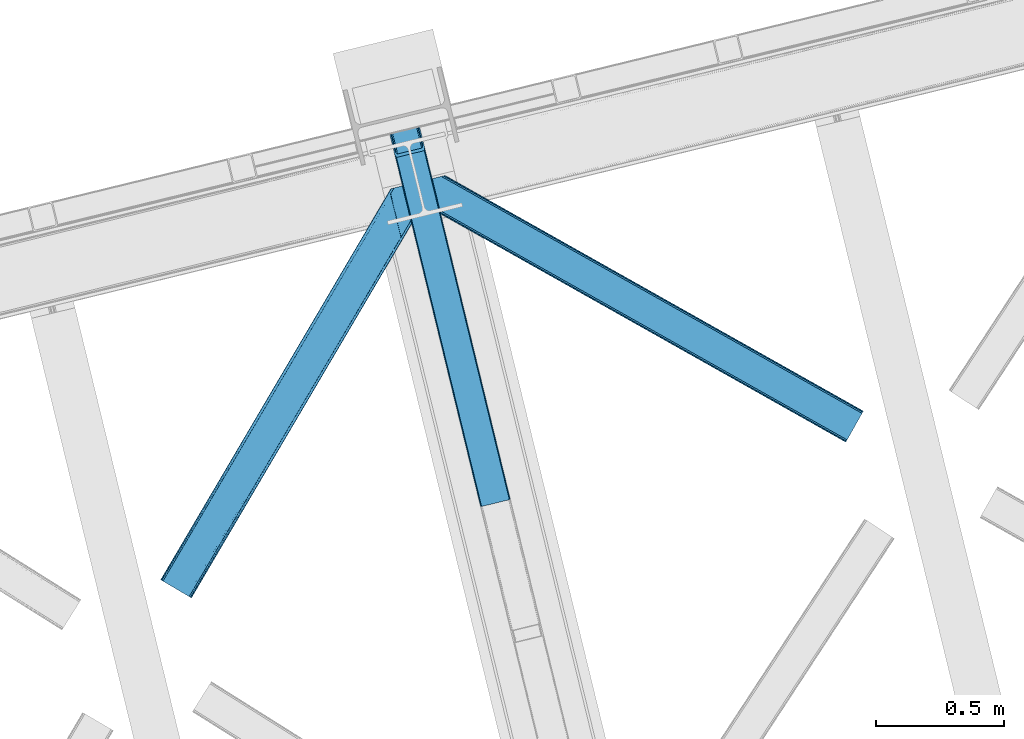
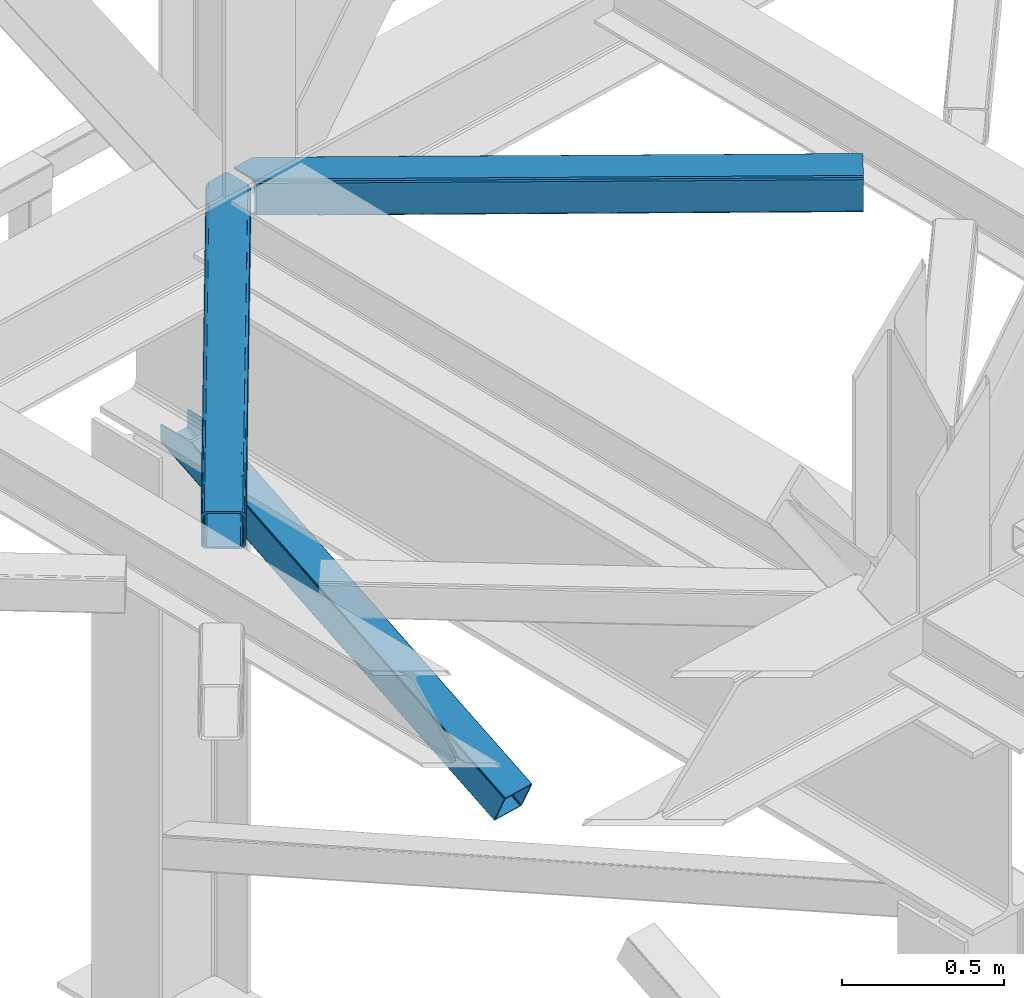
# One storey, part 39 of 93: 3 members.
"""IFC4 building model written with IfcOpenShell, lengths in millimetres."""

from ifc_helpers import new_model, entity, si_unit, converted_unit, derived_unit, direction, frame, origin, place, context, subcontext, project, spatial, triangles, type_object, element, save


model = new_model("IFC4")

# Units and contexts
model_context = context("Model", 3, precision=0.01, world=origin(), true_north=direction((6.12303176911189e-17, 1.0)))
plan_context = context("Plan", 3, precision=0.01, world=origin(), true_north=direction((6.12303176911189e-17, 1.0)))
body_context = subcontext(model_context, "Body", "Model", "MODEL_VIEW")
ifc_project = project(units=[si_unit("LENGTHUNIT", "METRE", prefix="MILLI"), si_unit("AREAUNIT", "SQUARE_METRE"), si_unit("VOLUMEUNIT", "CUBIC_METRE"), converted_unit("PLANEANGLEUNIT", "DEGREE", entity("IfcRatioMeasure", 0.0174532925199433), si_unit("PLANEANGLEUNIT", "RADIAN"), dimensions=[0, 0, 0, 0, 0, 0, 0]), si_unit("MASSUNIT", "GRAM", prefix="KILO"), derived_unit("MASSDENSITYUNIT", [(si_unit("MASSUNIT", "GRAM", prefix="KILO"), 1), (si_unit("LENGTHUNIT", "METRE"), -3)]), derived_unit("MOMENTOFINERTIAUNIT", [(si_unit("LENGTHUNIT", "METRE"), 4)]), si_unit("TIMEUNIT", "SECOND"), si_unit("FREQUENCYUNIT", "HERTZ"), si_unit("THERMODYNAMICTEMPERATUREUNIT", "DEGREE_CELSIUS"), derived_unit("THERMALTRANSMITTANCEUNIT", [(si_unit("MASSUNIT", "GRAM", prefix="KILO"), 1), (si_unit("THERMODYNAMICTEMPERATUREUNIT", "KELVIN"), -1), (si_unit("TIMEUNIT", "SECOND"), -3)]), derived_unit("VOLUMETRICFLOWRATEUNIT", [(si_unit("LENGTHUNIT", "METRE"), 3), (si_unit("TIMEUNIT", "SECOND"), -1)]), derived_unit("MASSFLOWRATEUNIT", [(si_unit("MASSUNIT", "GRAM", prefix="KILO"), 1), (si_unit("TIMEUNIT", "SECOND"), -1)]), derived_unit("ROTATIONALFREQUENCYUNIT", [(si_unit("TIMEUNIT", "SECOND"), -1)]), si_unit("ELECTRICCURRENTUNIT", "AMPERE"), si_unit("ELECTRICVOLTAGEUNIT", "VOLT"), si_unit("POWERUNIT", "WATT"), si_unit("FORCEUNIT", "NEWTON", prefix="KILO"), si_unit("ILLUMINANCEUNIT", "LUX"), si_unit("LUMINOUSFLUXUNIT", "LUMEN"), si_unit("LUMINOUSINTENSITYUNIT", "CANDELA"), derived_unit("USERDEFINED", [(si_unit("MASSUNIT", "GRAM", prefix="KILO"), -1), (si_unit("LENGTHUNIT", "METRE"), -2), (si_unit("TIMEUNIT", "SECOND"), 3), (si_unit("LUMINOUSFLUXUNIT", "LUMEN"), 1)]), derived_unit("LINEARVELOCITYUNIT", [(si_unit("LENGTHUNIT", "METRE"), 1), (si_unit("TIMEUNIT", "SECOND"), -1)]), si_unit("PRESSUREUNIT", "PASCAL"), derived_unit("USERDEFINED", [(si_unit("LENGTHUNIT", "METRE"), -2), (si_unit("MASSUNIT", "GRAM", prefix="KILO"), 1), (si_unit("TIMEUNIT", "SECOND"), -2)]), derived_unit("LINEARFORCEUNIT", [(si_unit("MASSUNIT", "GRAM", prefix="KILO"), 1), (si_unit("LENGTHUNIT", "METRE"), 1), (si_unit("TIMEUNIT", "SECOND"), -2), (si_unit("LENGTHUNIT", "METRE"), -1)]), derived_unit("PLANARFORCEUNIT", [(si_unit("MASSUNIT", "GRAM", prefix="KILO"), 1), (si_unit("LENGTHUNIT", "METRE"), 1), (si_unit("TIMEUNIT", "SECOND"), -2), (si_unit("LENGTHUNIT", "METRE"), -2)])], contexts=[model_context, plan_context])

# Site, building, storey
site_placement = place(None, origin())
site = spatial("IfcSite", under=ifc_project, at=site_placement, CompositionType="ELEMENT")
building_placement = place(site_placement, origin())
building = spatial("IfcBuilding", under=site, at=building_placement, CompositionType="ELEMENT")
storey_placement = place(building_placement, frame((0.0, 0.0, 15900.0)))
storey = spatial("IfcBuildingStorey", under=building, at=storey_placement, CompositionType="ELEMENT", Elevation=15900.0)

# Members
member_type_1 = type_object("IfcMemberType", PredefinedType="BRACE")
member_1_placement = place(storey_placement, frame((-49464.9481567383, 7483.36647949219, 1850.35374755859)))
element("IfcMember", 1, at=member_1_placement, inside=storey, type_object=member_type_1, ObjectType="Steel Vertical Brace", PredefinedType="BRACE", context=body_context, shape_type="Tessellation", body=[
    triangles([(109.783996582031, 1519.24680175781, 671.707836914062), (462.204345703125, 73.4908630371092, 0.0), (359.21993408203, 48.3871627807621, 0.0), (6.79958496093604, 1494.14310150146, 671.707836914062), (464.855346679688, 73.9117675781254, 0.48601684570167), (467.213342285155, 73.843167114258, 1.86965332031104), (112.188500976561, 1519.8328125, 672.832186889649), (468.906262207034, 73.2949447631836, 3.93929443359229), (114.593005371091, 1520.41940460205, 673.956536865233), (469.682958984376, 72.3502349853516, 6.38100585937354), (115.588293457033, 1520.66183166504, 676.672650146484), (116.583581542967, 1520.90484008789, 679.387600708007), (353.099377441409, 43.9310394287113, 6.38100585937354), (0.0, 1492.48564453125, 679.387600708007), (0.99528808593459, 1492.72807159424, 676.672650146484), (353.355175781253, 45.128059387207, 3.93929443359229), (1.99057617187646, 1492.97108001709, 673.956536865233), (354.606262207031, 46.3954238891602, 1.86965332031104), (4.39508056640625, 1493.55767211914, 672.832186889649), (356.666601562501, 47.5395401000978, 0.48601684570167), (144.93533935547, 1404.59159088135, 741.646591186523), (116.583581542967, 1520.90484008789, 741.646591186523), (480.012561035153, 29.9807281494141, 102.993713378906), (28.3517578125029, 1376.17239532471, 741.646591186523), (0.0, 1492.48564453125, 741.646591186523), (363.428979492186, 1.5615325927738, 102.993713378906), (476.445336914061, 26.3722274780275, 108.888702392578), (144.460949707034, 1388.29607391357, 741.646591186523), (142.168066406251, 1386.40316619873, 741.646591186523), (473.896655273435, 25.5251861572269, 109.37471923828), (478.505676269531, 27.5169250488279, 107.505065917969), (145.795751953126, 1392.41733398437, 741.646591186523), (479.75676269531, 28.7837081909183, 105.435424804688), (145.963183593747, 1398.13907775879, 741.646591186523), (39.1790039062471, 1361.29946594238, 741.646591186523), (370.907592773438, 0.421485900878906, 109.37471923828), (364.205676269528, 0.61682281494177, 105.435424804688), (30.4120971679658, 1369.97219238281, 741.646591186523), (365.90324707031, 0.0686004638673694, 107.505065917969), (33.1933227539048, 1364.96900939941, 741.646591186523), (368.256591796875, 0.0, 108.888702392578), (36.2722045898408, 1361.92384643555, 741.646591186523), (138.056689453122, 1403.03994140625, 741.646591186523), (137.200927734375, 1415.21477966309, 741.646591186523), (111.728063964845, 1519.72061004639, 741.646591186523), (138.22412109375, 1408.76284790039, 741.646591186523), (136.726538085939, 1398.91926269531, 741.646591186523), (134.429003906247, 1397.02635498047, 741.646591186523), (35.169946289061, 1377.96065826416, 741.646591186523), (32.3887207031221, 1382.96384124756, 741.646591186523), (30.333032226561, 1389.16346282959, 741.646591186523), (4.85551757812209, 1493.66987457275, 741.646591186523), (38.2534790039063, 1374.91549530029, 741.646591186523), (41.1602783203125, 1374.29111480713, 741.646591186523), (474.668701171875, 30.7952133178715, 98.4370147705085), (474.412902832031, 29.5981933593748, 100.87872619629), (473.157165527344, 28.3308288574217, 102.948367309571), (471.101477050783, 27.186712646484, 104.330841064453), (468.548144531247, 26.3390899658207, 104.816857910155), (375.279418945313, 3.60384979248011, 104.816857910155), (372.62841796875, 3.18294525146484, 104.330841064453), (370.270422363283, 3.25154571533221, 102.948367309571), (368.577502441403, 3.79976806640661, 100.87872619629), (367.796154785159, 4.74447784423865, 98.4370147705085), (111.728063964845, 1519.72061004639, 684.873312377931), (465.315783691403, 69.1678710937504, 10.9377044677749), (4.85551757812209, 1493.66987457275, 684.873312377931), (358.443237304688, 43.1165542602539, 10.9377044677749), (462.84151611328, 70.6602218627932, 6.42635192871239), (464.534436035159, 70.1125808715824, 8.49599304199364), (460.483520507813, 70.7294036865233, 5.04387817382667), (457.83251953125, 70.3079177856443, 4.557861328125), (359.954772949219, 45.5809387207028, 6.42635192871239), (362.01046142578, 46.7256362915041, 5.04387817382667), (358.699035644531, 44.3135742187496, 8.49599304199364), (364.563793945315, 47.5726776123047, 4.557861328125), (11.6551025390654, 1495.32733154297, 677.193548583986), (9.25059814452834, 1494.74132080078, 678.31789855957), (6.84609374999854, 1494.15531005859, 679.443411254884), (104.923828125, 1518.06257171631, 677.193548583986), (107.332983398439, 1518.64916381836, 678.31789855957), (109.73283691406, 1519.23517456055, 679.443411254884), (5.85080566406396, 1493.91288299561, 682.158361816408), (110.732775878903, 1519.47760162354, 682.158361816408)], [[1, 2, 3], [3, 4, 1], [5, 2, 1], [6, 5, 7], [8, 6, 9], [10, 8, 11], [11, 12, 10], [9, 11, 8], [7, 9, 6], [1, 7, 5], [13, 14, 15], [16, 15, 17], [18, 17, 19], [20, 19, 4], [4, 3, 20], [19, 20, 18], [17, 18, 16], [15, 16, 13], [12, 21, 10], [21, 12, 22], [23, 10, 21], [24, 14, 13], [24, 25, 14], [13, 26, 24], [27, 28, 29], [29, 30, 27], [31, 32, 28], [28, 27, 31], [33, 34, 32], [32, 31, 33], [23, 21, 34], [34, 33, 23], [30, 29, 35], [35, 36, 30], [37, 38, 26], [24, 26, 38], [39, 40, 37], [38, 37, 40], [41, 42, 39], [40, 39, 42], [36, 35, 41], [42, 41, 35], [43, 34, 21], [22, 44, 21], [44, 22, 45], [44, 46, 21], [46, 43, 21], [47, 34, 43], [32, 29, 28], [32, 34, 47], [32, 48, 29], [29, 48, 35], [47, 48, 32], [24, 38, 49], [49, 50, 24], [50, 51, 24], [51, 25, 24], [52, 25, 51], [38, 53, 49], [54, 40, 35], [54, 35, 48], [54, 53, 40], [35, 40, 42], [53, 38, 40], [44, 55, 46], [56, 46, 55], [46, 56, 43], [57, 43, 56], [43, 57, 47], [58, 47, 57], [47, 58, 48], [59, 48, 58], [48, 59, 54], [60, 54, 59], [54, 60, 61], [61, 53, 54], [53, 61, 62], [62, 49, 53], [49, 62, 63], [63, 50, 49], [50, 63, 64], [64, 51, 50], [44, 65, 66], [44, 45, 65], [66, 55, 44], [67, 51, 68], [51, 67, 52], [64, 68, 51], [55, 23, 56], [57, 33, 31], [31, 27, 57], [23, 55, 10], [23, 33, 57], [57, 56, 23], [59, 30, 36], [30, 58, 57], [59, 58, 30], [30, 57, 27], [6, 69, 5], [66, 10, 55], [69, 8, 10], [70, 10, 66], [8, 69, 6], [69, 2, 5], [10, 70, 69], [69, 71, 2], [2, 72, 3], [72, 2, 71], [62, 26, 63], [36, 60, 59], [61, 36, 62], [36, 61, 60], [62, 36, 41], [64, 63, 26], [41, 39, 62], [37, 62, 39], [64, 26, 13], [37, 26, 62], [73, 20, 3], [74, 73, 3], [75, 13, 73], [76, 3, 72], [3, 76, 74], [18, 20, 73], [13, 68, 64], [16, 73, 13], [68, 13, 75], [73, 16, 18], [77, 1, 4], [4, 19, 78], [19, 17, 15], [19, 79, 78], [4, 78, 77], [79, 19, 15], [80, 1, 77], [9, 7, 11], [7, 1, 81], [81, 82, 7], [7, 82, 11], [80, 81, 1], [11, 82, 12], [83, 14, 67], [15, 14, 79], [83, 79, 14], [25, 67, 14], [25, 52, 67], [12, 84, 65], [84, 12, 82], [65, 22, 12], [22, 65, 45], [72, 80, 76], [77, 76, 80], [66, 65, 84], [70, 84, 82], [69, 82, 81], [71, 81, 80], [80, 72, 71], [81, 71, 69], [82, 69, 70], [84, 70, 66], [74, 76, 77], [73, 74, 78], [75, 73, 79], [68, 75, 83], [83, 67, 68], [79, 83, 75], [78, 79, 73], [77, 78, 74]]),
])
member_type_2 = type_object("IfcMemberType", PredefinedType="BRACE")
member_2_placement = place(storey_placement, frame((-49332.8771484375, 7733.54713897705, 3511.0000579834)))
element("IfcMember", 2, at=member_2_placement, inside=storey, type_object=member_type_2, ObjectType="Steel Horizontal Brace", PredefinedType="BRACE", context=body_context, shape_type="Tessellation", body=[
    triangles([(1656.08961181641, 0.0, 122.500662231447), (1656.74538574219, 1.16039428710974, 129.197927856447), (23.8915649414048, 919.17296447754, 122.500662231447), (23.4590332031294, 920.94494934082, 129.197927856447), (1658.60573730469, 4.46600646972638, 134.874325561526), (22.2265502929731, 925.991734313965, 134.874325561526), (1661.39161376953, 9.41279754638708, 138.667117309571), (20.3894531250044, 933.544180297852, 138.667117309571), (1664.67513427734, 15.2484878540045, 139.999594116212), (18.2174926757798, 942.452938842774, 139.999594116212), (1656.08961181641, 0.0, 17.5000946044929), (23.8915649414048, 919.17296447754, 17.5000946044929), (1716.19757080078, 106.738252258301, 139.999594116212), (69.4469238281235, 1034.10722808838, 139.999594116212), (0.0, 1017.17919158936, 139.999594116212), (1719.4857421875, 112.573361206055, 138.667117309571), (78.971923828125, 1036.42917938232, 138.667117309571), (1722.27161865235, 117.520152282715, 134.874325561526), (87.0458496093779, 1038.39766387939, 134.874325561526), (1724.13197021485, 120.825764465332, 129.197927856447), (92.4408691406279, 1039.71269989014, 129.197927856447), (1724.78774414062, 121.986740112305, 122.500662231447), (94.3384277343794, 1040.17488098145, 122.500662231447), (1724.78774414062, 121.986740112305, 17.5000946044929), (94.3384277343794, 1040.17488098145, 17.5000946044929), (1656.74538574219, 1.16039428710974, 10.8028289794929), (1658.60573730469, 4.46600646972638, 5.12526855468968), (196.057800292969, 824.821165466309, 8.8831787109375), (196.076403808598, 825.066499328613, 8.50064392089917), (23.3706665039063, 921.307136535645, 10.8691040039084), (195.062512207034, 824.99848022461, 9.50058288574292), (195.732238769531, 824.878720092774, 9.08316650390771), (23.263696289061, 921.747807312012, 9.50058288574292), (195.220642089844, 828.57035522461, 5.12526855468968), (1664.67513427734, 15.2484878540045, 0.0), (1661.39161376953, 9.41279754638708, 1.33247680664135), (193.378894042973, 836.122801208497, 1.33247680664135), (191.206933593749, 845.031559753418, 0.0), (1716.19757080078, 106.738252258301, 0.0), (157.162499999999, 984.71082458496, 0.0), (191.346459960936, 843.22294921875, 9.20757751465135), (191.290649414063, 844.06824645996, 8.85411071777344), (191.104614257813, 845.460603332519, 8.41343994140698), (18.8686157226548, 939.774032592774, 9.50058288574292), (1724.13197021485, 120.825764465332, 10.8028289794929), (92.0548461914077, 1039.61851959229, 10.8702667236357), (150.921020507813, 1006.08800811768, 9.50058288574292), (1722.27161865235, 117.520152282715, 5.12526855468968), (153.148791503911, 1001.17202911377, 5.12526855468968), (152.293029785156, 1004.67588500977, 8.50064392089917), (151.60469970703, 1005.38223724365, 9.00061340332104), (91.5851074218735, 1039.50341033936, 9.50058288574292), (1719.4857421875, 112.573361206055, 1.33247680664135), (154.990539550781, 993.619583129884, 1.33247680664135), (156.250927734378, 986.702563476562, 9.11688537597729), (155.813745117186, 987.634483337403, 9.42384338378906), (156.692761230472, 985.76134185791, 8.80760192871094), (157.129943847656, 984.828840637208, 8.50064392089917), (155.316101074219, 988.061782836915, 9.50058288574292), (72.3118652343765, 1034.80544128418, 9.50058288574292), (159.43212890625, 975.399183654786, 6.99957275390625), (188.937304687504, 854.343782043456, 6.99957275390625), (1668.11213378907, 21.3475341796875, 6.99957275390625), (1712.76522216797, 100.639205932617, 6.99957275390625), (19.9569213867217, 935.303375244142, 12.1260040283232), (1662.0380859375, 10.5650527954103, 12.1260040283232), (1664.82396240235, 15.5124252319338, 8.3320495605476), (1659.52661132813, 6.09904632568396, 24.4996673583992), (1660.177734375, 7.26002197265643, 17.8035644531265), (21.6219360351606, 928.485186767578, 24.4996673583992), (21.1894042968779, 930.25717163086, 17.8035644531265), (1716.04874267578, 106.474314880371, 8.3320495605476), (1718.83927001953, 111.421105957032, 12.1260040283232), (77.0929687500029, 1035.9704864502, 12.1260040283232), (1720.69962158203, 114.726718139648, 17.8035644531265), (82.4879882812529, 1037.2861038208, 17.8035644531265), (1721.35074462891, 115.887112426758, 24.4996673583992), (84.3808959960952, 1037.74770355225, 24.4996673583992), (1659.52661132813, 6.09904632568396, 115.501089477541), (21.6219360351606, 928.485186767578, 115.501089477541), (21.1894042968779, 930.25717163086, 122.196029663086), (19.9569213867217, 935.303375244142, 127.87475280762), (15.9478637695356, 951.765161132812, 133.000021362306), (18.1198242187529, 942.855821228027, 131.667544555665), (0.0, 1017.17919158936, 133.000021362306), (1668.11213378907, 21.3475341796875, 133.000021362306), (1664.82396240235, 15.5124252319338, 131.667544555665), (1662.0380859375, 10.5650527954103, 127.87475280762), (1660.177734375, 7.26002197265643, 122.196029663086), (1718.83927001953, 111.421105957032, 127.87475280762), (1720.69962158203, 114.726718139648, 122.196029663086), (1721.35074462891, 115.887112426758, 115.501089477541), (1712.76522216797, 100.639205932617, 133.000021362306), (1716.04874267578, 106.474314880371, 131.667544555665), (77.0929687500029, 1035.9704864502, 127.87475280762), (69.0143920898481, 1034.00200195312, 131.667544555665), (82.4879882812529, 1037.2861038208, 122.196029663086), (59.4893920898467, 1031.68005065918, 133.000021362306), (84.3808959960952, 1037.74770355225, 115.501089477541)], [[1, 2, 3], [4, 3, 2], [2, 5, 4], [6, 4, 5], [5, 7, 6], [8, 6, 7], [7, 9, 8], [10, 8, 9], [11, 1, 12], [3, 12, 1], [13, 10, 9], [10, 13, 14], [15, 10, 14], [13, 16, 17], [17, 14, 13], [16, 18, 19], [19, 17, 16], [18, 20, 21], [21, 19, 18], [20, 22, 23], [23, 21, 20], [22, 24, 23], [25, 23, 24], [26, 11, 12], [27, 28, 29], [26, 30, 31], [31, 27, 26], [31, 32, 27], [30, 33, 31], [29, 34, 27], [35, 36, 37], [37, 38, 35], [36, 27, 34], [34, 37, 36], [12, 30, 26], [39, 35, 38], [38, 40, 39], [41, 42, 29], [42, 43, 29], [41, 31, 33], [33, 44, 41], [45, 46, 25], [46, 45, 47], [45, 48, 49], [49, 50, 45], [45, 50, 51], [51, 47, 45], [47, 52, 46], [48, 53, 54], [54, 49, 48], [53, 39, 40], [40, 54, 53], [25, 24, 45], [51, 55, 56], [50, 57, 55], [50, 58, 57], [47, 59, 52], [60, 52, 59], [61, 40, 62], [54, 58, 49], [58, 54, 40], [49, 58, 50], [40, 61, 58], [62, 40, 38], [37, 43, 38], [43, 37, 34], [38, 43, 62], [34, 29, 43], [63, 64, 62], [61, 62, 64], [63, 62, 43], [41, 65, 66], [41, 44, 65], [43, 66, 67], [66, 43, 42], [42, 41, 66], [43, 67, 63], [68, 69, 70], [71, 70, 69], [69, 66, 71], [65, 71, 66], [72, 58, 61], [57, 72, 55], [57, 58, 72], [56, 55, 72], [73, 74, 59], [59, 72, 73], [74, 60, 59], [73, 75, 76], [76, 74, 73], [75, 77, 78], [78, 76, 75], [61, 64, 72], [79, 68, 80], [70, 80, 68], [81, 6, 82], [80, 70, 3], [4, 81, 3], [81, 4, 6], [81, 80, 3], [70, 12, 3], [71, 65, 33], [33, 30, 71], [30, 12, 71], [70, 71, 12], [83, 10, 15], [10, 84, 8], [84, 10, 83], [15, 85, 83], [84, 82, 8], [44, 33, 65], [8, 82, 6], [86, 87, 84], [84, 83, 86], [87, 88, 82], [82, 84, 87], [88, 89, 81], [81, 82, 88], [89, 79, 80], [80, 81, 89], [20, 90, 91], [92, 24, 22], [20, 91, 22], [20, 18, 90], [91, 92, 22], [90, 18, 16], [93, 13, 9], [13, 94, 16], [94, 13, 93], [94, 90, 16], [45, 73, 48], [77, 24, 92], [24, 75, 45], [75, 24, 77], [45, 75, 73], [39, 64, 35], [53, 48, 73], [73, 72, 53], [72, 64, 39], [39, 53, 72], [88, 7, 5], [9, 86, 93], [9, 87, 86], [87, 9, 7], [88, 87, 7], [79, 1, 11], [2, 89, 88], [5, 2, 88], [89, 2, 1], [79, 89, 1], [36, 66, 27], [35, 64, 63], [63, 67, 35], [67, 66, 36], [36, 35, 67], [26, 27, 66], [11, 68, 79], [69, 11, 26], [11, 69, 68], [69, 26, 66], [95, 96, 17], [19, 95, 17], [19, 21, 97], [95, 19, 97], [97, 21, 23], [96, 14, 17], [15, 98, 85], [15, 14, 98], [96, 98, 14], [97, 23, 99], [78, 25, 76], [23, 78, 99], [25, 46, 76], [23, 25, 78], [52, 76, 46], [74, 76, 52], [60, 74, 52], [93, 83, 98], [93, 86, 83], [83, 85, 98], [77, 92, 99], [99, 78, 77], [92, 91, 99], [97, 99, 91], [91, 90, 97], [95, 97, 90], [90, 94, 95], [96, 95, 94], [94, 93, 96], [98, 96, 93]]),
])
member_type_3 = type_object("IfcMemberType", PredefinedType="BRACE")
member_3_placement = place(storey_placement, frame((-50348.2756347656, 7126.42373199463, 3511.0000579834)))
element("IfcMember", 3, at=member_3_placement, inside=storey, type_object=member_type_3, ObjectType="Steel Horizontal Brace", PredefinedType="BRACE", context=body_context, shape_type="Tessellation", body=[
    triangles([(105.565649414064, 8.87852783203198, 0.0), (15.0828002929702, 62.1485321044929, 0.0), (892.847827148435, 1346.13992614746, 0.0), (857.170935058595, 1492.50308532715, 0.0), (854.896655273435, 1501.83798065186, 1.33247680664135), (9.31105957031104, 65.5459991455082, 1.33247680664135), (852.966540527341, 1509.7520324707, 5.12526855468968), (4.4183349609375, 68.4266372680668, 5.12526855468968), (851.678247070311, 1515.03950042725, 10.8028289794929), (1.14876708984229, 70.3509384155277, 10.8028289794929), (851.222460937497, 1516.89636383057, 17.5000946044929), (0.0, 71.027059936524, 17.5000946044929), (893.638476562497, 1342.89826354981, 0.155804443362285), (111.337390136716, 5.48106079101581, 1.33247680664135), (899.559045410155, 1344.34178009033, 1.33247680664135), (912.390820312496, 1347.47007751465, 10.8028289794929), (914.195361328122, 1347.90958557129, 17.5000946044929), (120.643798828125, 0.0, 17.5000946044929), (119.499682617185, 0.676121520996276, 10.8028289794929), (907.251599121089, 1346.21724700928, 5.12526855468968), (116.230114746089, 2.60042266845721, 5.12526855468968), (902.498400878903, 1345.05743408203, 17.9802978515654), (893.638476562497, 1342.89826354981, 9.69243164062573), (897.768457031249, 1343.90517883301, 12.1260040283232), (903.726232910158, 1345.35683441162, 19.4999725341804), (914.195361328122, 1347.90958557129, 19.4999725341804), (1011.61732177734, 1513.38669433594, 19.4999725341804), (1008.98957519531, 1524.16103668213, 19.4999725341804), (1011.61732177734, 1513.38669433594, 122.500662231447), (120.643798828125, 0.0, 122.500662231447), (114.61160888672, 3.5515274047857, 24.4996673583992), (1009.24072265625, 1523.14423828125, 24.4996673583992), (113.462841796871, 4.22706756591833, 17.8035644531265), (110.197924804685, 6.15195007324292, 12.1260040283232), (105.305200195311, 9.03200683593786, 8.3320495605476), (99.5334594726519, 12.4294738769531, 6.99957275390625), (892.685046386716, 1346.80035095215, 8.88434143066479), (890.471228027345, 1355.89747009277, 6.99957275390625), (21.114990234375, 58.5975860595709, 6.99957275390625), (859.547534179685, 1482.74496002197, 6.99957275390625), (853.961828613283, 1505.66042175293, 18.5000335693367), (851.222460937497, 1516.89636383057, 18.5000335693367), (854.096704101561, 1505.10929260254, 17.8803039550803), (855.343139648438, 1499.99448852539, 12.1260040283232), (857.273254394531, 1492.08043670654, 8.3320495605476), (1009.24072265625, 1523.14423828125, 115.501089477541), (114.61160888672, 3.5515274047857, 115.501089477541), (1008.78493652344, 1525.00110168457, 122.196029663086), (113.462841796871, 4.22706756591833, 122.196029663086), (1007.49664306641, 1530.28915100098, 127.87475280762), (110.197924804685, 6.15195007324292, 127.87475280762), (1005.57117919921, 1538.20320281983, 131.667544555665), (105.305200195311, 9.03200683593786, 131.667544555665), (1003.29224853515, 1547.53809814453, 133.000021362306), (99.5334594726519, 12.4294738769531, 133.000021362306), (851.952648925777, 1518.13291625977, 19.4999725341804), (854.580395507808, 1507.35857391358, 19.4999725341804), (851.780566406247, 1517.84049224854, 19.2639404296897), (854.43156738281, 1506.95045928955, 19.2592895507842), (851.589880371095, 1517.5149307251, 19.0000030517585), (854.268786621091, 1506.50978851318, 19.0000030517585), (851.394543457027, 1517.1887878418, 18.736065673831), (854.110656738281, 1506.06853637695, 18.7407165527366), (908.014343261719, 1598.12687072754, 19.4999725341804), (897.545214843747, 1595.57411956787, 19.4999725341804), (1011.16618652343, 1515.24355773926, 129.197927856447), (1009.8778930664, 1520.53160705566, 134.874325561526), (1008.43146972656, 1526.45624542236, 137.999716186525), (986.311889648438, 1617.21175231934, 137.999716186525), (986.311889648438, 1617.21175231934, 133.000021362306), (897.545214843747, 1595.57411956787, 122.500662231447), (0.0, 71.027059936524, 122.500662231447), (7.18095703124709, 66.7999923706057, 17.8035644531265), (10.4505249023423, 64.875109863282, 12.1260040283232), (6.03218994140479, 67.4755325317383, 24.4996673583992), (907.028356933595, 1597.88560638428, 24.4996673583992), (15.3432495117158, 61.9950531005861, 8.3320495605476), (908.832897949214, 1598.32569580078, 122.196029663086), (899.349755859374, 1596.01362762451, 129.197927856447), (904.48897705078, 1597.26645812988, 134.874325561526), (930.738537597652, 1603.66548614502, 133.000021362306), (910.246765136719, 1598.67044219971, 137.999716186525), (921.664672851563, 1601.45341186523, 131.667544555665), (913.972119140621, 1599.57852630615, 127.87475280762), (907.028356933595, 1597.88560638428, 115.501089477541), (21.114990234375, 58.5975860595709, 133.000021362306), (6.03218994140479, 67.4755325317383, 115.501089477541), (15.3432495117158, 61.9950531005861, 131.667544555665), (10.4505249023423, 64.875109863282, 127.87475280762), (7.18095703124709, 66.7999923706057, 122.196029663086), (119.499682617185, 0.676121520996276, 129.197927856447), (116.230114746089, 2.60042266845721, 134.874325561526), (111.337390136716, 5.48106079101581, 138.667117309571), (105.565649414064, 8.87852783203198, 139.999594116212), (15.0828002929702, 62.1485321044929, 139.999594116212), (9.31105957031104, 65.5459991455082, 138.667117309571), (4.4183349609375, 68.4266372680668, 134.874325561526), (1.14876708984229, 70.3509384155277, 129.197927856447), (896.991760253906, 1576.15611877441, 137.999716186525), (938.18924560547, 1407.14434204102, 137.999716186525), (899.024194335936, 1563.59525756836, 139.999594116212), (897.042919921871, 1571.7232498169, 138.999655151369), (896.801074218747, 1573.1371170044, 138.639212036134), (896.926647949214, 1575.15443572998, 138.211331176761), (896.86153564453, 1574.14170684815, 138.427597045898), (937.477661132813, 1407.08620605469, 138.29272155762), (937.082336425781, 1408.09544677734, 138.646188354494), (936.682360839841, 1409.1046875, 138.999655151369), (934.701086425783, 1417.23267974854, 139.999594116212)], [[1, 2, 3], [4, 3, 2], [5, 4, 6], [2, 6, 4], [7, 5, 8], [6, 8, 5], [9, 7, 10], [8, 10, 7], [11, 9, 12], [10, 12, 9], [1, 3, 13], [13, 14, 1], [13, 15, 14], [16, 17, 18], [18, 19, 16], [20, 16, 19], [19, 21, 20], [15, 20, 21], [21, 14, 15], [20, 22, 16], [23, 24, 15], [23, 15, 13], [15, 24, 20], [16, 25, 17], [20, 24, 22], [16, 22, 25], [26, 17, 25], [26, 25, 27], [28, 27, 25], [27, 29, 26], [30, 26, 29], [26, 18, 17], [30, 18, 26], [31, 32, 25], [25, 33, 31], [25, 22, 33], [32, 28, 25], [33, 22, 24], [34, 24, 23], [23, 35, 34], [36, 35, 37], [37, 38, 36], [23, 37, 35], [24, 34, 33], [39, 36, 38], [38, 40, 39], [9, 11, 41], [11, 42, 41], [43, 9, 41], [43, 7, 9], [44, 7, 43], [5, 44, 45], [44, 5, 7], [4, 5, 45], [45, 40, 4], [37, 23, 13], [37, 3, 38], [3, 40, 38], [40, 3, 4], [37, 13, 3], [46, 32, 31], [31, 47, 46], [48, 46, 49], [47, 49, 46], [50, 48, 51], [49, 51, 48], [52, 50, 53], [51, 53, 50], [54, 52, 55], [53, 55, 52], [56, 57, 58], [59, 58, 57], [58, 59, 60], [61, 60, 59], [60, 61, 62], [63, 62, 61], [62, 63, 42], [41, 42, 63], [57, 56, 64], [65, 64, 56], [66, 48, 67], [46, 29, 27], [27, 32, 46], [32, 27, 28], [48, 29, 46], [66, 29, 48], [50, 68, 67], [52, 68, 50], [67, 48, 50], [52, 54, 68], [54, 69, 68], [70, 69, 54], [71, 60, 62], [58, 60, 71], [71, 56, 58], [56, 71, 65], [42, 12, 72], [12, 42, 11], [71, 42, 72], [42, 71, 62], [73, 74, 44], [75, 73, 43], [43, 41, 75], [43, 57, 75], [64, 76, 57], [75, 57, 76], [44, 43, 73], [45, 44, 74], [74, 77, 45], [40, 45, 77], [77, 39, 40], [78, 79, 80], [81, 82, 69], [69, 70, 81], [81, 83, 82], [84, 82, 83], [80, 82, 84], [78, 71, 79], [85, 71, 78], [80, 84, 78], [65, 76, 64], [85, 65, 71], [76, 65, 85], [86, 54, 55], [54, 86, 81], [70, 54, 81], [76, 85, 87], [87, 75, 76], [83, 81, 86], [86, 88, 83], [84, 83, 88], [88, 89, 84], [78, 84, 89], [89, 90, 78], [85, 78, 90], [90, 87, 85], [91, 51, 49], [47, 18, 30], [91, 49, 30], [91, 92, 51], [49, 47, 30], [51, 92, 93], [55, 94, 95], [94, 53, 93], [53, 94, 55], [53, 51, 93], [19, 34, 21], [31, 18, 47], [18, 33, 19], [33, 18, 31], [19, 33, 34], [1, 36, 2], [14, 21, 34], [34, 35, 14], [35, 36, 1], [1, 14, 35], [89, 96, 97], [95, 86, 55], [95, 88, 86], [88, 95, 96], [89, 88, 96], [87, 72, 12], [98, 90, 89], [97, 98, 89], [90, 98, 72], [87, 90, 72], [6, 74, 8], [2, 36, 39], [39, 77, 2], [77, 74, 6], [6, 2, 77], [10, 8, 74], [12, 75, 87], [73, 12, 10], [12, 73, 75], [73, 10, 74], [99, 68, 82], [99, 100, 68], [68, 69, 82], [96, 95, 101], [101, 102, 96], [97, 96, 103], [104, 97, 105], [104, 99, 97], [97, 103, 105], [82, 80, 99], [97, 99, 80], [102, 103, 96], [79, 71, 98], [72, 98, 71], [80, 79, 97], [98, 97, 79], [92, 67, 100], [100, 93, 92], [67, 68, 100], [106, 107, 93], [94, 93, 107], [107, 108, 94], [108, 109, 94], [66, 67, 92], [92, 91, 66], [29, 66, 91], [91, 30, 29], [95, 94, 109], [109, 101, 95], [107, 103, 102], [105, 103, 107], [106, 104, 105], [100, 99, 104], [107, 106, 105], [102, 108, 107], [102, 101, 109], [109, 108, 102]]),
])

save(model, "model.ifc")
